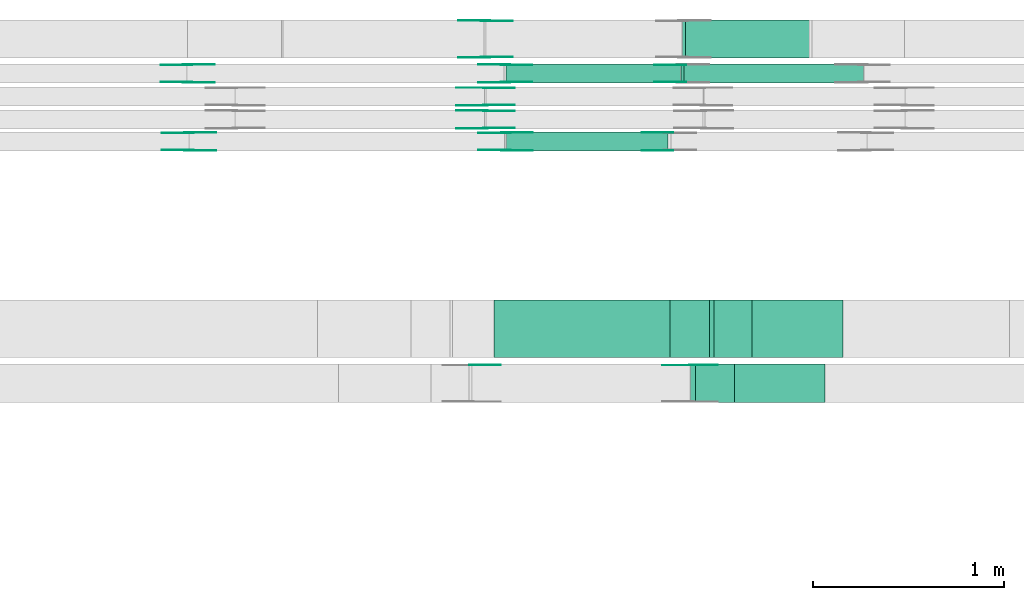
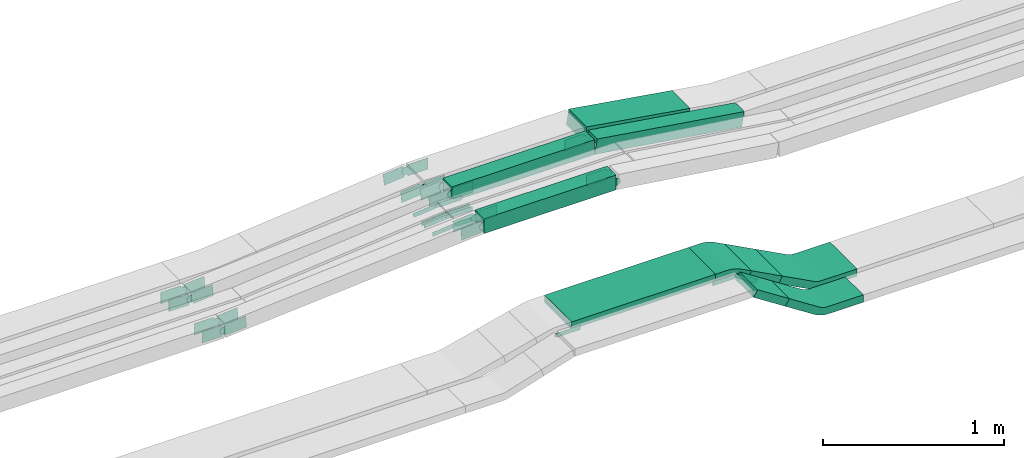
# One storey, part 19 of 31: 38 flow fittings, 7 flow segments.
"""IFC2X3 building model written with IfcOpenShell, lengths in millimetres."""

from ifc_helpers import new_model, entity, si_unit, converted_unit, derived_unit, direction, frame, frame_2d, origin, origin_2d_with_axis, place, context, subcontext, project, spatial, polyline, circle_curve, parameter, trimmed, segment, composite_curve, rectangle, outline, extrude, source, transform, mapped, material, type_object, type_shapes, element, save


model = new_model("IFC2X3")

# Units and contexts
model_context = context("Model", 3, precision=0.01, world=origin(), true_north=direction((6.12303176911189e-17, 1.0)))
body_context = subcontext(model_context, "Body", "Model", "MODEL_VIEW")
ifc_project = project(units=[si_unit("LENGTHUNIT", "METRE", prefix="MILLI"), si_unit("AREAUNIT", "SQUARE_METRE"), si_unit("VOLUMEUNIT", "CUBIC_METRE"), converted_unit("PLANEANGLEUNIT", "DEGREE", entity("IfcRatioMeasure", 0.0174532925199433), si_unit("PLANEANGLEUNIT", "RADIAN"), dimensions=[0, 0, 0, 0, 0, 0, 0]), si_unit("MASSUNIT", "GRAM", prefix="KILO"), derived_unit("MASSDENSITYUNIT", [(si_unit("MASSUNIT", "GRAM", prefix="KILO"), 1), (si_unit("LENGTHUNIT", "METRE"), -3)]), derived_unit("MOMENTOFINERTIAUNIT", [(si_unit("LENGTHUNIT", "METRE"), 4)]), si_unit("TIMEUNIT", "SECOND"), si_unit("FREQUENCYUNIT", "HERTZ"), si_unit("THERMODYNAMICTEMPERATUREUNIT", "DEGREE_CELSIUS"), derived_unit("THERMALTRANSMITTANCEUNIT", [(si_unit("MASSUNIT", "GRAM", prefix="KILO"), 1), (si_unit("THERMODYNAMICTEMPERATUREUNIT", "KELVIN"), -1), (si_unit("TIMEUNIT", "SECOND"), -3)]), derived_unit("VOLUMETRICFLOWRATEUNIT", [(si_unit("LENGTHUNIT", "METRE"), 3), (si_unit("TIMEUNIT", "SECOND"), -1)]), derived_unit("MASSFLOWRATEUNIT", [(si_unit("MASSUNIT", "GRAM", prefix="KILO"), 1), (si_unit("TIMEUNIT", "SECOND"), -1)]), derived_unit("ROTATIONALFREQUENCYUNIT", [(si_unit("TIMEUNIT", "SECOND"), -1)]), si_unit("ELECTRICCURRENTUNIT", "AMPERE"), si_unit("ELECTRICVOLTAGEUNIT", "VOLT"), si_unit("POWERUNIT", "WATT"), si_unit("FORCEUNIT", "NEWTON", prefix="KILO"), si_unit("ILLUMINANCEUNIT", "LUX"), si_unit("LUMINOUSFLUXUNIT", "LUMEN"), si_unit("LUMINOUSINTENSITYUNIT", "CANDELA"), derived_unit("USERDEFINED", [(si_unit("MASSUNIT", "GRAM", prefix="KILO"), -1), (si_unit("LENGTHUNIT", "METRE"), -2), (si_unit("TIMEUNIT", "SECOND"), 3), (si_unit("LUMINOUSFLUXUNIT", "LUMEN"), 1)]), derived_unit("LINEARVELOCITYUNIT", [(si_unit("LENGTHUNIT", "METRE"), 1), (si_unit("TIMEUNIT", "SECOND"), -1)]), si_unit("PRESSUREUNIT", "PASCAL"), derived_unit("USERDEFINED", [(si_unit("LENGTHUNIT", "METRE"), -2), (si_unit("MASSUNIT", "GRAM", prefix="KILO"), 1), (si_unit("TIMEUNIT", "SECOND"), -2)]), derived_unit("LINEARFORCEUNIT", [(si_unit("MASSUNIT", "GRAM", prefix="KILO"), 1), (si_unit("LENGTHUNIT", "METRE"), 1), (si_unit("TIMEUNIT", "SECOND"), -2), (si_unit("LENGTHUNIT", "METRE"), -1)]), derived_unit("PLANARFORCEUNIT", [(si_unit("MASSUNIT", "GRAM", prefix="KILO"), 1), (si_unit("LENGTHUNIT", "METRE"), 1), (si_unit("TIMEUNIT", "SECOND"), -2), (si_unit("LENGTHUNIT", "METRE"), -2)])], contexts=[model_context])

# Site, building, storey
site_placement = place(None, frame((0.0, -0.00077364408347762, 0.0)))
site = spatial("IfcSite", under=ifc_project, at=site_placement, CompositionType="ELEMENT")
building_placement = place(site_placement, origin())
building = spatial("IfcBuilding", under=site, at=building_placement, CompositionType="ELEMENT")
storey_placement = place(building_placement, frame((0.0, 0.0, 15900.0)))
storey = spatial("IfcBuildingStorey", under=building, at=storey_placement, CompositionType="ELEMENT", Elevation=15900.0)

# Flow segments
cable_carrier_segment_type = type_object("IfcCableCarrierSegmentType", PredefinedType="CABLETRAYSEGMENT")
flow_segment_1_placement = place(storey_placement, frame((50695.7211648117, 15869.9939089947, 2760.0)))
element("IfcFlowSegment", 1, at=flow_segment_1_placement, inside=storey, type_object=cable_carrier_segment_type, context=body_context, shape_type="SweptSolid", body=[
    extrude(rectangle(XDim=911.872890053045, YDim=99.9999999999989, at=origin_2d_with_axis()), frame((455.936445026522, 50.0, 0.0), z_axis=(0.0, 0.0, 1.0), x_axis=(-1.0, 0.0, 0.0)), (0.0, 0.0, 1.0), 99.9999999999989),
])
flow_segment_2_placement = place(storey_placement, frame((50697.7327239431, 15514.9939089947, 2759.606473505)))
element("IfcFlowSegment", 2, at=flow_segment_2_placement, inside=storey, type_object=cable_carrier_segment_type, context=body_context, shape_type="SweptSolid", body=[
    extrude(rectangle(XDim=843.799195165727, YDim=99.9999999999989, at=origin_2d_with_axis()), frame((421.899597582864, 50.0, 0.0)), (0.0, 0.0, 1.0), 99.9999999999989),
])
flow_segment_3_placement = place(storey_placement, frame((51610.1865296066, 15869.9939089947, 2616.34322964053)))
element("IfcFlowSegment", 3, at=flow_segment_3_placement, inside=storey, type_object=cable_carrier_segment_type, context=body_context, shape_type="SweptSolid", body=[
    extrude(rectangle(XDim=100.000000000002, YDim=99.9999999999989, at=origin_2d_with_axis()), frame((7.5492329480742, 50.0, 192.886735421527), z_axis=(0.988536105945672, 0.0, -0.150984658961655), x_axis=(0.150984658961655, 0.0, 0.988536105945672)), (0.0, 0.0, 1.0), 950.162295367439),
])
flow_segment_4_placement = place(storey_placement, frame((51618.2100690014, 15999.9939089947, 2654.57160601323)))
element("IfcFlowSegment", 4, at=flow_segment_4_placement, inside=storey, type_object=cable_carrier_segment_type, context=body_context, shape_type="SweptSolid", body=[
    extrude(rectangle(XDim=100.000000000002, YDim=200.000000000002, at=frame_2d((2.16715534406831e-12, 0.0), x_axis=(0.0, 1.0))), frame((7.86505725246589, 100.0, 154.598829676428), z_axis=(0.987550682125342, 0.0, -0.157301145049142), x_axis=(0.0, 1.0, 0.0)), (0.0, 0.0, 1.0), 668.916272270489),
])
flow_segment_5_placement = place(storey_placement, frame((50633.0291109772, 14435.0255085139, 2790.0)))
element("IfcFlowSegment", 5, at=flow_segment_5_placement, inside=storey, type_object=cable_carrier_segment_type, context=body_context, shape_type="SweptSolid", body=[
    extrude(rectangle(XDim=920.040761116609, YDim=300.000000000001, at=origin_2d_with_axis()), frame((460.020380558305, 150.0, 0.0), z_axis=(0.0, 0.0, 1.0), x_axis=(-1.0, 0.0, 0.0)), (0.0, 0.0, 1.0), 50.0000000000016),
])
flow_segment_6_placement = place(storey_placement, frame((51759.6943798342, 14435.0255085139, 2634.07453731288)))
element("IfcFlowSegment", 6, at=flow_segment_6_placement, inside=storey, type_object=cable_carrier_segment_type, context=body_context, shape_type="SweptSolid", body=[
    extrude(rectangle(XDim=50.0000000000009, YDim=223.849365682387, at=frame_2d((5.04485342389671e-13, 9.59232693276135e-13), x_axis=(0.0, 1.0))), frame((110.627807503583, 0.0, 74.4255877616074), z_axis=(0.0, 1.0, 0.0), x_axis=(0.883987864537297, 0.0, -0.467509845191296)), (0.0, 0.0, 1.0), 300.000000000001),
])
flow_segment_7_placement = place(storey_placement, frame((51660.107770543, 14200.0255085138, 2657.65794976646)))
element("IfcFlowSegment", 7, at=flow_segment_7_placement, inside=storey, type_object=cable_carrier_segment_type, context=body_context, shape_type="SweptSolid", body=[
    extrude(rectangle(XDim=49.9999999999933, YDim=200.000000000002, at=frame_2d((0.0, 0.0), x_axis=(0.0, 1.0))), frame((13.5813457098757, 100.0, 152.146283107953), z_axis=(0.839568506992544, 0.0, -0.543253828395448), x_axis=(0.0, 1.0, 0.0)), (0.0, 0.0, 1.0), 241.428708971117),
])

# Flow fittings
ifc_material_1 = material(Name="G")
cable_carrier_fitting_type_1 = type_object("IfcCableCarrierFittingType", PredefinedType="NOTDEFINED", material=ifc_material_1)
shared_shape_1 = source(origin(), body_context, "Body", "SweptSolid", [
    extrude(outline(composite_curve([segment(trimmed(circle_curve(frame_2d((-44.5901162790698, 0.0), x_axis=(1.0, 0.0)), 12.5), [parameter(90.0000000000007)], [parameter(270.0)], True, "PARAMETER"), True, "CONTINUOUS"), segment(polyline([(-44.5901162790697, -12.5), (-33.0901162790698, -12.5)]), True, "CONTINUOUS"), segment(polyline([(-33.0901162790698, -12.5), (-31.2296511627907, -14.5)]), True, "CONTINUOUS"), segment(polyline([(-31.2296511627907, -14.5), (108.90988372093, -14.5)]), True, "CONTINUOUS"), segment(polyline([(108.90988372093, -14.5), (108.90988372093, 14.5)]), True, "CONTINUOUS"), segment(polyline([(108.90988372093, 14.5), (-31.2296511627907, 14.5)]), True, "CONTINUOUS"), segment(polyline([(-31.2296511627907, 14.5), (-33.0901162790698, 12.5)]), True, "CONTINUOUS"), segment(polyline([(-33.0901162790698, 12.5), (-44.5901162790699, 12.5)]), True, "CONTINUOUS")], self_intersect=False)), frame((44.5901162790698, 0.0, 0.0), z_axis=(0.0, 0.0, -1.0), x_axis=(1.0, 0.0, 0.0)), (0.0, 0.0, -1.0), 2.0),
])
type_shapes(cable_carrier_fitting_type_1, [shared_shape_1])
for number, where, z_axis, x_axis in (
    (8, (50588.3617929942, 15633.9980000417, 2787.19977544197), (0.0, -1.0, 0.0), (-0.995479968225886, 0.0, -0.0949717476989256)),
    (9, (50588.3617929942, 15753.9980000417, 2787.19977544197), (0.0, -1.0, 0.0), (-0.995479968225886, 0.0, -0.0949717476989256)),
    (10, (50514.6820523198, 14395.485508524, 2815.0), (0.0, 1.0, 0.0), (1.0, 0.0, 0.0)),
    (11, (51665.6593478089, 14395.485508524, 2815.0), (0.0, 1.0, 0.0), (0.839568506992486, 0.0, -0.543253828395537)),
):
    element("IfcFlowFitting", number, at=place(storey_placement, frame(where, z_axis=z_axis, x_axis=x_axis)), inside=storey, type_object=cable_carrier_fitting_type_1, material=ifc_material_1, context=body_context, shape_type="MappedRepresentation", body=[
        mapped(shared_shape_1, transform((0.0, 0.0, 0.0), scale=1.0)),
    ])
cable_carrier_fitting_type_2 = type_object("IfcCableCarrierFittingType", PredefinedType="NOTDEFINED", material=ifc_material_1)
shared_shape_2 = source(origin(), body_context, "Body", "SweptSolid", [
    extrude(outline(composite_curve([segment(trimmed(circle_curve(frame_2d((-44.5901162790697, 0.0), x_axis=(1.0, 0.0)), 12.5), [parameter(90.0000000000007)], [parameter(270.0)], True, "PARAMETER"), True, "CONTINUOUS"), segment(polyline([(-44.5901162790697, -12.5), (-33.0901162790697, -12.5)]), True, "CONTINUOUS"), segment(polyline([(-33.0901162790697, -12.5), (-31.2296511627907, -14.5)]), True, "CONTINUOUS"), segment(polyline([(-31.2296511627907, -14.5), (108.90988372093, -14.5)]), True, "CONTINUOUS"), segment(polyline([(108.90988372093, -14.5), (108.90988372093, 14.5)]), True, "CONTINUOUS"), segment(polyline([(108.90988372093, 14.5), (-31.2296511627907, 14.5)]), True, "CONTINUOUS"), segment(polyline([(-31.2296511627907, 14.5), (-33.0901162790698, 12.5)]), True, "CONTINUOUS"), segment(polyline([(-33.0901162790698, 12.5), (-44.5901162790699, 12.5)]), True, "CONTINUOUS")], self_intersect=False)), frame((44.5901162790697, 0.0, 0.0)), (0.0, 0.0, 1.0), 2.0),
])
type_shapes(cable_carrier_fitting_type_2, [shared_shape_2])
for number, where, z_axis, x_axis in (
    (12, (50588.3617929942, 15724.918000062, 2787.19977544197), (0.0, 1.0, 0.0), (-0.995479968225886, 0.0, -0.0949717476989256)),
    (13, (50588.3617929942, 15844.918000062, 2787.19977544197), (0.0, 1.0, 0.0), (-0.995479968225886, 0.0, -0.0949717476989256)),
):
    element("IfcFlowFitting", number, at=place(storey_placement, frame(where, z_axis=z_axis, x_axis=x_axis)), inside=storey, type_object=cable_carrier_fitting_type_2, material=ifc_material_1, context=body_context, shape_type="MappedRepresentation", body=[
        mapped(shared_shape_2, transform((0.0, 0.0, 0.0), scale=1.0)),
    ])
cable_carrier_fitting_type_3 = type_object("IfcCableCarrierFittingType", PredefinedType="NOTDEFINED", material=ifc_material_1)
shared_shape_3 = source(origin(), body_context, "Body", "SweptSolid", [
    extrude(outline(composite_curve([segment(trimmed(circle_curve(frame_2d((-44.5901162790698, 0.0), x_axis=(1.0, 0.0)), 12.5), [parameter(90.0000000000007)], [parameter(270.0)], True, "PARAMETER"), True, "CONTINUOUS"), segment(polyline([(-44.5901162790697, -12.5), (-33.0901162790698, -12.5)]), True, "CONTINUOUS"), segment(polyline([(-33.0901162790698, -12.5), (-31.2296511627907, -14.5)]), True, "CONTINUOUS"), segment(polyline([(-31.2296511627907, -14.5), (108.90988372093, -14.5)]), True, "CONTINUOUS"), segment(polyline([(108.90988372093, -14.5), (108.90988372093, 14.5)]), True, "CONTINUOUS"), segment(polyline([(108.90988372093, 14.5), (-31.2296511627907, 14.5)]), True, "CONTINUOUS"), segment(polyline([(-31.2296511627907, 14.5), (-33.0901162790698, 12.5)]), True, "CONTINUOUS"), segment(polyline([(-33.0901162790698, 12.5), (-44.5901162790699, 12.5)]), True, "CONTINUOUS")], self_intersect=False)), frame((44.5901162790698, 0.0, 0.0), z_axis=(0.0, 0.0, -1.0), x_axis=(1.0, 0.0, 0.0)), (0.0, 0.0, -1.0), 2.0),
])
type_shapes(cable_carrier_fitting_type_3, [shared_shape_3])
for number, where, z_axis, x_axis in (
    (14, (50588.3617929941, 15722.918000062, 2787.19977544196), (0.0, 1.0, 0.0), (1.0, 0.0, 0.0)),
    (15, (50588.3617929941, 15842.918000062, 2787.19977544196), (0.0, 1.0, 0.0), (1.0, 0.0, 0.0)),
):
    element("IfcFlowFitting", number, at=place(storey_placement, frame(where, z_axis=z_axis, x_axis=x_axis)), inside=storey, type_object=cable_carrier_fitting_type_3, material=ifc_material_1, context=body_context, shape_type="MappedRepresentation", body=[
        mapped(shared_shape_3, transform((0.0, 0.0, 0.0), scale=1.0)),
    ])
cable_carrier_fitting_type_4 = type_object("IfcCableCarrierFittingType", PredefinedType="NOTDEFINED", material=ifc_material_1)
shared_shape_4 = source(origin(), body_context, "Body", "SweptSolid", [
    extrude(outline(composite_curve([segment(trimmed(circle_curve(frame_2d((-44.5901162790697, 0.0), x_axis=(1.0, 0.0)), 12.5), [parameter(90.0000000000007)], [parameter(270.0)], True, "PARAMETER"), True, "CONTINUOUS"), segment(polyline([(-44.5901162790697, -12.5), (-33.0901162790697, -12.5)]), True, "CONTINUOUS"), segment(polyline([(-33.0901162790697, -12.5), (-31.2296511627907, -14.5)]), True, "CONTINUOUS"), segment(polyline([(-31.2296511627907, -14.5), (108.90988372093, -14.5)]), True, "CONTINUOUS"), segment(polyline([(108.90988372093, -14.5), (108.90988372093, 14.5)]), True, "CONTINUOUS"), segment(polyline([(108.90988372093, 14.5), (-31.2296511627907, 14.5)]), True, "CONTINUOUS"), segment(polyline([(-31.2296511627907, 14.5), (-33.0901162790698, 12.5)]), True, "CONTINUOUS"), segment(polyline([(-33.0901162790698, 12.5), (-44.5901162790699, 12.5)]), True, "CONTINUOUS")], self_intersect=False)), frame((44.5901162790697, 0.0, 0.0)), (0.0, 0.0, 1.0), 2.0),
])
type_shapes(cable_carrier_fitting_type_4, [shared_shape_4])
for number, where, z_axis, x_axis in (
    (16, (50588.3617929941, 15635.9980000417, 2787.19977544196), (0.0, -1.0, 0.0), (1.0, 0.0, 0.0)),
    (17, (50588.3617929941, 15755.9980000417, 2787.19977544196), (0.0, -1.0, 0.0), (1.0, 0.0, 0.0)),
    (18, (51665.6593478089, 14393.485508524, 2815.0), (0.0, 1.0, 0.0), (-1.0, 0.0, 0.0)),
):
    element("IfcFlowFitting", number, at=place(storey_placement, frame(where, z_axis=z_axis, x_axis=x_axis)), inside=storey, type_object=cable_carrier_fitting_type_4, material=ifc_material_1, context=body_context, shape_type="MappedRepresentation", body=[
        mapped(shared_shape_4, transform((0.0, 0.0, 0.0), scale=1.0)),
    ])
cable_carrier_fitting_type_5 = type_object("IfcCableCarrierFittingType", PredefinedType="NOTDEFINED", material=ifc_material_1)
shared_shape_5 = source(origin(), body_context, "Body", "SweptSolid", [
    extrude(outline(composite_curve([segment(trimmed(circle_curve(frame_2d((-41.4651162790697, 0.0), x_axis=(1.0, 0.0)), 25.0), [parameter(90.0000000000007)], [parameter(270.0)], True, "PARAMETER"), True, "CONTINUOUS"), segment(polyline([(-41.4651162790697, -25.0), (-29.9651162790697, -25.0)]), True, "CONTINUOUS"), segment(polyline([(-29.9651162790697, -25.0), (-28.1046511627907, -38.5)]), True, "CONTINUOUS"), segment(polyline([(-28.1046511627907, -38.5), (99.5348837209303, -38.5)]), True, "CONTINUOUS"), segment(polyline([(99.5348837209303, -38.5), (99.5348837209303, 38.5)]), True, "CONTINUOUS"), segment(polyline([(99.5348837209303, 38.5), (-28.1046511627907, 38.5)]), True, "CONTINUOUS"), segment(polyline([(-28.1046511627907, 38.5), (-29.9651162790697, 25.0)]), True, "CONTINUOUS"), segment(polyline([(-29.9651162790697, 25.0), (-41.46511627907, 25.0)]), True, "CONTINUOUS")], self_intersect=False)), frame((41.4651162790697, 0.0, 0.0), z_axis=(0.0, 0.0, -1.0), x_axis=(1.0, 0.0, 0.0)), (0.0, 0.0, -1.0), 2.0),
])
type_shapes(cable_carrier_fitting_type_5, [shared_shape_5])
for number, where, z_axis, x_axis in (
    (19, (50692.6941421397, 15874.5339089846, 2810.0), (0.0, -1.0, 0.0), (-0.997185843977155, 0.0, -0.0749692775179912)),
    (20, (50694.7047220472, 15610.4539090049, 2809.60647350501), (0.0, 1.0, 0.0), (1.0, 0.0, 0.0)),
    (21, (51546.2436932262, 15519.5339089845, 2809.60647350501), (0.0, -1.0, 0.0), (-1.0, 0.0, 0.0)),
    (22, (49030.0366559812, 15874.5339089846, 2685.0), (0.0, -1.0, 0.0), (0.997185843977155, 0.0, 0.0749692775179912)),
    (23, (49037.4136342253, 15519.5339089845, 2684.94956318966), (0.0, -1.0, 0.0), (0.997183128198858, 0.0, 0.0750053920431093)),
    (24, (50588.7187437624, 16004.5339089845, 2810.0), (0.0, -1.0, 0.0), (-0.995479968225886, 0.0, -0.0949717476989308)),
):
    element("IfcFlowFitting", number, at=place(storey_placement, frame(where, z_axis=z_axis, x_axis=x_axis)), inside=storey, type_object=cable_carrier_fitting_type_5, material=ifc_material_1, context=body_context, shape_type="MappedRepresentation", body=[
        mapped(shared_shape_5, transform((0.0, 0.0, 0.0), scale=1.0)),
    ])
cable_carrier_fitting_type_6 = type_object("IfcCableCarrierFittingType", PredefinedType="NOTDEFINED", material=ifc_material_1)
shared_shape_6 = source(origin(), body_context, "Body", "SweptSolid", [
    extrude(outline(composite_curve([segment(trimmed(circle_curve(frame_2d((-41.4651162790697, 0.0), x_axis=(1.0, 0.0)), 25.0), [parameter(90.0000000000007)], [parameter(270.0)], True, "PARAMETER"), True, "CONTINUOUS"), segment(polyline([(-41.4651162790697, -25.0), (-29.9651162790697, -25.0)]), True, "CONTINUOUS"), segment(polyline([(-29.9651162790697, -25.0), (-28.1046511627907, -38.5)]), True, "CONTINUOUS"), segment(polyline([(-28.1046511627907, -38.5), (99.5348837209303, -38.5)]), True, "CONTINUOUS"), segment(polyline([(99.5348837209303, -38.5), (99.5348837209303, 38.5)]), True, "CONTINUOUS"), segment(polyline([(99.5348837209303, 38.5), (-28.1046511627907, 38.5)]), True, "CONTINUOUS"), segment(polyline([(-28.1046511627907, 38.5), (-29.9651162790697, 25.0)]), True, "CONTINUOUS"), segment(polyline([(-29.9651162790697, 25.0), (-41.46511627907, 25.0)]), True, "CONTINUOUS")], self_intersect=False)), frame((41.4651162790697, 0.0, 0.0)), (0.0, 0.0, 1.0), 2.0),
])
type_shapes(cable_carrier_fitting_type_6, [shared_shape_6])
for number, where, z_axis, x_axis in (
    (25, (50692.6941421397, 15965.4539090049, 2810.0), (0.0, 1.0, 0.0), (-0.997185843977155, 0.0, -0.0749692775179912)),
    (26, (50694.7047220472, 15519.5339089845, 2809.60647350501), (0.0, -1.0, 0.0), (1.0, 0.0, 0.0)),
    (27, (51546.2436932262, 15610.4539090049, 2809.60647350502), (0.0, 1.0, 0.0), (-1.0, 0.0, 0.0)),
    (28, (49030.0366559812, 15965.4539090049, 2685.0), (0.0, 1.0, 0.0), (0.997185843977155, 0.0, 0.0749692775179912)),
    (29, (49037.4136342253, 15610.4539090049, 2684.94956318966), (0.0, 1.0, 0.0), (0.997183128198858, 0.0, 0.0750053920431093)),
    (30, (50588.7187437624, 16195.4539090048, 2810.0), (0.0, 1.0, 0.0), (-0.995479968225886, 0.0, -0.0949717476989308)),
):
    element("IfcFlowFitting", number, at=place(storey_placement, frame(where, z_axis=z_axis, x_axis=x_axis)), inside=storey, type_object=cable_carrier_fitting_type_6, material=ifc_material_1, context=body_context, shape_type="MappedRepresentation", body=[
        mapped(shared_shape_6, transform((0.0, 0.0, 0.0), scale=1.0)),
    ])
cable_carrier_fitting_type_7 = type_object("IfcCableCarrierFittingType", PredefinedType="NOTDEFINED", material=ifc_material_1)
shared_shape_7 = source(origin(), body_context, "Body", "SweptSolid", [
    extrude(outline(composite_curve([segment(trimmed(circle_curve(frame_2d((-41.4651162790697, 0.0), x_axis=(1.0, 0.0)), 25.0), [parameter(90.0000000000007)], [parameter(270.0)], True, "PARAMETER"), True, "CONTINUOUS"), segment(polyline([(-41.4651162790697, -25.0), (-29.9651162790697, -25.0)]), True, "CONTINUOUS"), segment(polyline([(-29.9651162790697, -25.0), (-28.1046511627907, -38.5)]), True, "CONTINUOUS"), segment(polyline([(-28.1046511627907, -38.5), (99.5348837209303, -38.5)]), True, "CONTINUOUS"), segment(polyline([(99.5348837209303, -38.5), (99.5348837209303, 38.5)]), True, "CONTINUOUS"), segment(polyline([(99.5348837209303, 38.5), (-28.1046511627907, 38.5)]), True, "CONTINUOUS"), segment(polyline([(-28.1046511627907, 38.5), (-29.9651162790697, 25.0)]), True, "CONTINUOUS"), segment(polyline([(-29.9651162790697, 25.0), (-41.46511627907, 25.0)]), True, "CONTINUOUS")], self_intersect=False)), frame((41.4651162790697, 0.0, 0.0), z_axis=(0.0, 0.0, -1.0), x_axis=(1.0, 0.0, 0.0)), (0.0, 0.0, -1.0), 2.0),
])
type_shapes(cable_carrier_fitting_type_7, [shared_shape_7])
for number, where, z_axis, x_axis in (
    (31, (51612.6941421398, 15876.5339089845, 2810.0), (0.0, -1.0, 0.0), (-1.0, 0.0, 0.0)),
    (32, (50692.6941421397, 15963.4539090049, 2810.0), (0.0, 1.0, 0.0), (1.0, 0.0, 0.0)),
    (33, (50694.7047220472, 15521.5339089845, 2809.606473505), (0.0, -1.0, 0.0), (-0.997183128198489, 0.0, -0.075005392048013)),
    (34, (49030.0366559813, 15963.4539090049, 2685.0), (0.0, 1.0, 0.0), (-1.0, 0.0, 0.0)),
    (35, (49037.4136342253, 15608.4539090049, 2684.94956318966), (0.0, 1.0, 0.0), (-1.0, 0.0, 0.0)),
    (36, (50588.7187437624, 16193.4539090048, 2810.0), (0.0, 1.0, 0.0), (1.0, 0.0, 0.0)),
):
    element("IfcFlowFitting", number, at=place(storey_placement, frame(where, z_axis=z_axis, x_axis=x_axis)), inside=storey, type_object=cable_carrier_fitting_type_7, material=ifc_material_1, context=body_context, shape_type="MappedRepresentation", body=[
        mapped(shared_shape_7, transform((0.0, 0.0, 0.0), scale=1.0)),
    ])
cable_carrier_fitting_type_8 = type_object("IfcCableCarrierFittingType", PredefinedType="NOTDEFINED", material=ifc_material_1)
shared_shape_8 = source(origin(), body_context, "Body", "SweptSolid", [
    extrude(outline(composite_curve([segment(trimmed(circle_curve(frame_2d((-41.4651162790697, 0.0), x_axis=(1.0, 0.0)), 25.0), [parameter(90.0000000000007)], [parameter(270.0)], True, "PARAMETER"), True, "CONTINUOUS"), segment(polyline([(-41.4651162790697, -25.0), (-29.9651162790697, -25.0)]), True, "CONTINUOUS"), segment(polyline([(-29.9651162790697, -25.0), (-28.1046511627907, -38.5)]), True, "CONTINUOUS"), segment(polyline([(-28.1046511627907, -38.5), (99.5348837209303, -38.5)]), True, "CONTINUOUS"), segment(polyline([(99.5348837209303, -38.5), (99.5348837209303, 38.5)]), True, "CONTINUOUS"), segment(polyline([(99.5348837209303, 38.5), (-28.1046511627907, 38.5)]), True, "CONTINUOUS"), segment(polyline([(-28.1046511627907, 38.5), (-29.9651162790697, 25.0)]), True, "CONTINUOUS"), segment(polyline([(-29.9651162790697, 25.0), (-41.46511627907, 25.0)]), True, "CONTINUOUS")], self_intersect=False)), frame((41.4651162790697, 0.0, 0.0)), (0.0, 0.0, 1.0), 2.0),
])
type_shapes(cable_carrier_fitting_type_8, [shared_shape_8])
for number, where, z_axis, x_axis in (
    (37, (51612.6941421398, 15963.4539090049, 2810.0), (0.0, 1.0, 0.0), (-1.0, 0.0, 0.0)),
    (38, (50692.6941421397, 15876.5339089846, 2810.0), (0.0, -1.0, 0.0), (1.0, 0.0, 0.0)),
    (39, (50694.7047220472, 15608.4539090049, 2809.606473505), (0.0, 1.0, 0.0), (-0.997183128198489, 0.0, -0.075005392048013)),
    (40, (49030.0366559813, 15876.5339089846, 2685.0), (0.0, -1.0, 0.0), (-1.0, 0.0, 0.0)),
    (41, (49037.4136342253, 15521.5339089845, 2684.94956318966), (0.0, -1.0, 0.0), (-1.0, 0.0, 0.0)),
    (42, (50588.7187437624, 16006.5339089845, 2810.0), (0.0, -1.0, 0.0), (1.0, 0.0, 0.0)),
):
    element("IfcFlowFitting", number, at=place(storey_placement, frame(where, z_axis=z_axis, x_axis=x_axis)), inside=storey, type_object=cable_carrier_fitting_type_8, material=ifc_material_1, context=body_context, shape_type="MappedRepresentation", body=[
        mapped(shared_shape_8, transform((0.0, 0.0, 0.0), scale=1.0)),
    ])
ifc_material_2 = material()
cable_carrier_fitting_type_9 = type_object("IfcCableCarrierFittingType", Name="470_DKC_S5_CD 90 external vertical angle:-", PredefinedType="NOTDEFINED", material=ifc_material_2)
shared_shape_9 = source(origin(), body_context, "Body", "SweptSolid", [
    extrude(outline(composite_curve([segment(polyline([(-111.329415378405, -43.3289965321777), (-36.39627378498, -43.3289965321777)]), True, "CONTINUOUS"), segment(trimmed(circle_curve(frame_2d((-36.3962737849803, 146.671003467821), x_axis=(0.0, -1.0)), 189.999999999999), [parameter(0.0)], [parameter(27.8727762328618)], True, "PARAMETER"), True, "CONTINUOUS"), segment(polyline([(52.4305968013498, -21.2866907942725), (118.670584621595, 13.7452906317604)]), True, "CONTINUOUS"), segment(polyline([(118.670584621595, 13.7452906317604), (95.2950923620344, 57.9446838586277)]), True, "CONTINUOUS"), segment(polyline([(95.2950923620344, 57.9446838586277), (29.055104541789, 22.9127024325947)]), True, "CONTINUOUS"), segment(trimmed(circle_curve(frame_2d((-36.3962737849803, 146.671003467821), x_axis=(0.0, -1.0)), 139.999999999999), [parameter(0.0)], [parameter(27.8727762328618)], True, "PARAMETER"), False, "CONTINUOUS"), segment(polyline([(-36.39627378498, 6.67100346782259), (-111.329415378405, 6.67100346782258)]), True, "CONTINUOUS"), segment(polyline([(-111.329415378405, 6.67100346782258), (-111.329415378405, -43.3289965321777)]), True, "CONTINUOUS")], self_intersect=False)), frame((-4.54832352827097, 18.3289965321705, -150.0)), (0.0, 0.0, 1.0), 300.0),
])
type_shapes(cable_carrier_fitting_type_9, [shared_shape_9])
flow_fitting_1_placement = place(storey_placement, frame((51668.9476110004, 14585.0255085139, 2815.0), z_axis=(0.0, 1.0, 0.0), x_axis=(1.0, 0.0, 0.0)))
element("IfcFlowFitting", 43, at=flow_fitting_1_placement, inside=storey, type_object=cable_carrier_fitting_type_9, material=ifc_material_2, Name="470_DKC_S5_CD 90 external vertical angle:-", ObjectType="470_DKC_S5_CD 90 external vertical angle:-", context=body_context, shape_type="MappedRepresentation", body=[
    mapped(shared_shape_9, transform((0.0, 0.0, 0.0), scale=1.0)),
])
cable_carrier_fitting_type_10 = type_object("IfcCableCarrierFittingType", Name="470_DKC_S5_CS 90 internal vertical angle:-", PredefinedType="NOTDEFINED", material=ifc_material_2)
shared_shape_10 = source(origin(), body_context, "Body", "SweptSolid", [
    extrude(outline(composite_curve([segment(polyline([(-252.156420919518, -66.5268928656124), (-29.0806742132192, -66.5268928656124)]), True, "CONTINUOUS"), segment(trimmed(circle_curve(frame_2d((-29.0806742132194, 98.4731071343865), x_axis=(0.0, -1.0)), 164.999999999999), [parameter(0.0)], [parameter(32.9054169620784)], True, "PARAMETER"), True, "CONTINUOUS"), segment(polyline([(60.5562074720257, -40.0556965193843), (247.843579080482, 81.1310569009808)]), True, "CONTINUOUS"), segment(polyline([(247.843579080482, 81.1310569009808), (220.680887660711, 123.109482250609)]), True, "CONTINUOUS"), segment(polyline([(220.680887660711, 123.109482250609), (33.3935160522541, 1.92272883024371)]), True, "CONTINUOUS"), segment(trimmed(circle_curve(frame_2d((-29.0806742132194, 98.4731071343865), x_axis=(0.0, -1.0)), 114.999999999999), [parameter(0.0)], [parameter(32.9054169620784)], True, "PARAMETER"), False, "CONTINUOUS"), segment(polyline([(-29.0806742132192, -16.5268928656121), (-252.156420919518, -16.5268928656121)]), True, "CONTINUOUS"), segment(polyline([(-252.156420919518, -16.5268928656121), (-252.156420919518, -66.5268928656124)]), True, "CONTINUOUS")], self_intersect=False)), frame((-12.2635517214179, 41.5268928656051, -100.0)), (0.0, 0.0, 1.0), 200.0),
])
type_shapes(cable_carrier_fitting_type_10, [shared_shape_10])
flow_fitting_2_placement = place(storey_placement, frame((52098.3837386382, 14300.0255085139, 2535.0), z_axis=(0.0, -1.0, 0.0), x_axis=(0.839568506992486, 0.0, -0.543253828395537)))
element("IfcFlowFitting", 44, at=flow_fitting_2_placement, inside=storey, type_object=cable_carrier_fitting_type_10, material=ifc_material_2, Name="470_DKC_S5_CS 90 internal vertical angle:-", ObjectType="470_DKC_S5_CS 90 internal vertical angle:-", context=body_context, shape_type="MappedRepresentation", body=[
    mapped(shared_shape_10, transform((0.0, 0.0, 0.0), scale=1.0)),
])
cable_carrier_fitting_type_11 = type_object("IfcCableCarrierFittingType", Name="470_DKC_S5_CS 90 internal vertical angle:-", PredefinedType="NOTDEFINED", material=ifc_material_2)
shared_shape_11 = source(origin(), body_context, "Body", "SweptSolid", [
    extrude(outline(composite_curve([segment(polyline([(-250.665854797324, -59.3539832227788), (-26.2159613011708, -59.3539832227788)]), True, "CONTINUOUS"), segment(trimmed(circle_curve(frame_2d((-26.2159613011711, 105.64601677722), x_axis=(0.0, -1.0)), 164.999999999999), [parameter(0.0)], [parameter(27.8727762328618)], True, "PARAMETER"), True, "CONTINUOUS"), segment(polyline([(50.9231631553787, -40.2119808714401), (249.334145202676, 64.7205540901302)]), True, "CONTINUOUS"), segment(polyline([(249.334145202676, 64.7205540901302), (225.958652943115, 108.919947316998)]), True, "CONTINUOUS"), segment(polyline([(225.958652943115, 108.919947316997), (27.5476708958178, 3.98741235542717)]), True, "CONTINUOUS"), segment(trimmed(circle_curve(frame_2d((-26.2159613011711, 105.64601677722), x_axis=(0.0, -1.0)), 114.999999999999), [parameter(0.0)], [parameter(27.8727762328618)], True, "PARAMETER"), False, "CONTINUOUS"), segment(polyline([(-26.2159613011708, -9.35398322277854), (-250.665854797324, -9.35398322277852)]), True, "CONTINUOUS"), segment(polyline([(-250.665854797324, -9.35398322277852), (-250.665854797324, -59.3539832227788)]), True, "CONTINUOUS")], self_intersect=False)), frame((-8.52490914643466, 34.3539832227716, -150.0)), (0.0, 0.0, 1.0), 300.0),
])
type_shapes(cable_carrier_fitting_type_11, [shared_shape_11])
flow_fitting_3_placement = place(storey_placement, frame((52198.383738638, 14585.0255085139, 2535.0), z_axis=(0.0, -1.0, 0.0), x_axis=(0.883987864537297, 0.0, -0.467509845191296)))
element("IfcFlowFitting", 45, at=flow_fitting_3_placement, inside=storey, type_object=cable_carrier_fitting_type_11, material=ifc_material_2, Name="470_DKC_S5_CS 90 internal vertical angle:-", ObjectType="470_DKC_S5_CS 90 internal vertical angle:-", context=body_context, shape_type="MappedRepresentation", body=[
    mapped(shared_shape_11, transform((0.0, 0.0, 0.0), scale=1.0)),
])

save(model, "model.ifc")
